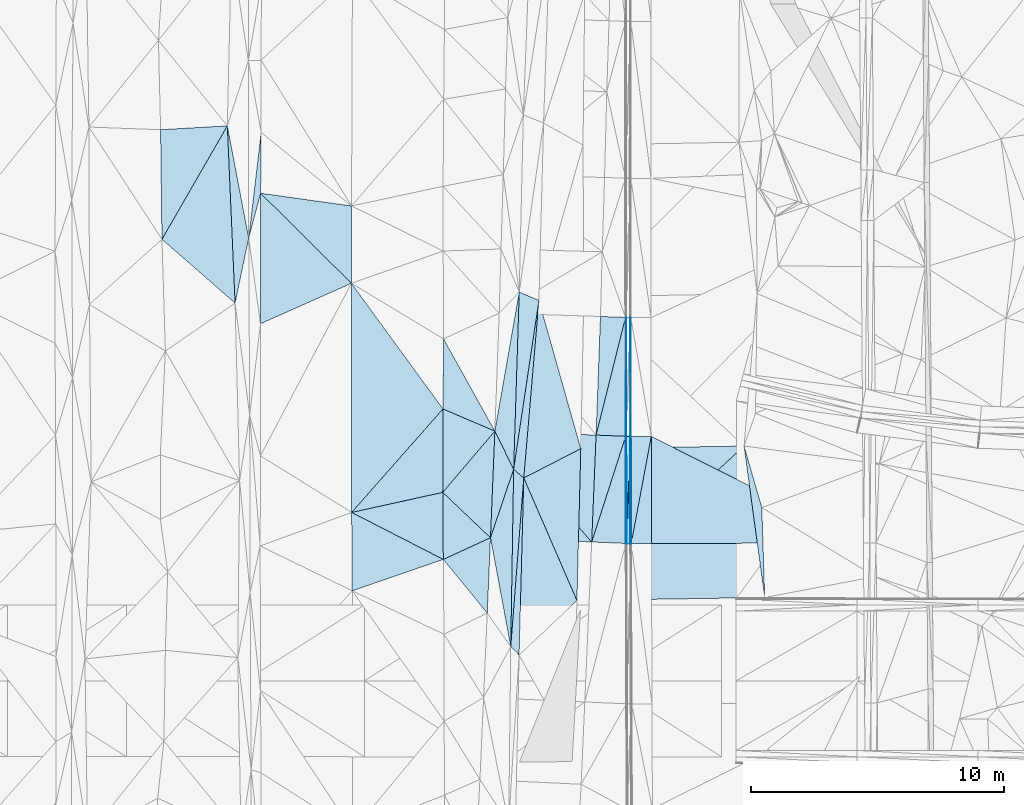
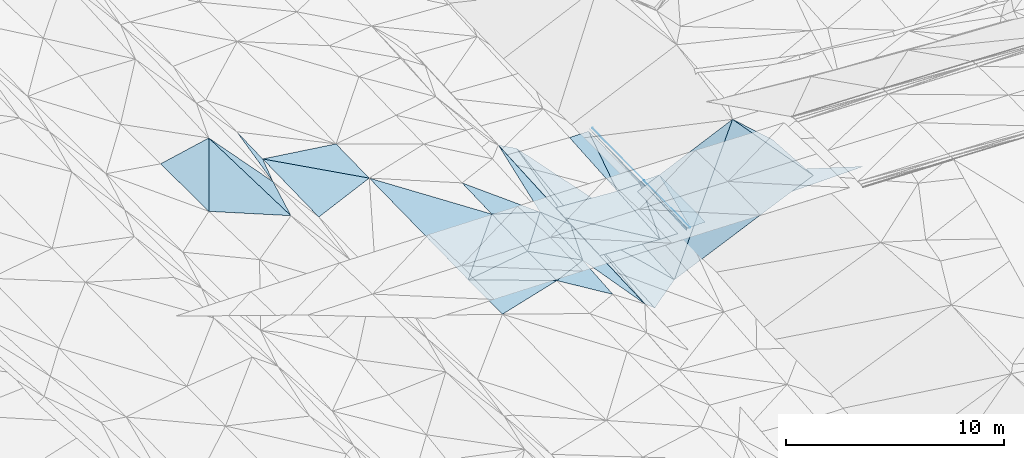
# One storey, part 109 of 275: 45 plates.
"""IFC2X3 building model written with IfcOpenShell, lengths in millimetres."""

from ifc_helpers import new_model, si_unit, frame, origin_with_axes, place, context, subcontext, project, spatial, polyline, outline, extrude, material, type_object, element, save


model = new_model("IFC2X3")

# Units and contexts
model_context = context("Model", 3, precision=1e-05, world=origin_with_axes())
body_context = subcontext(model_context, "Body", "Model", "MODEL_VIEW")
ifc_project = project(units=[si_unit("LENGTHUNIT", "METRE", prefix="MILLI"), si_unit("AREAUNIT", "SQUARE_METRE"), si_unit("VOLUMEUNIT", "CUBIC_METRE"), si_unit("MASSUNIT", "GRAM", prefix="KILO"), si_unit("TIMEUNIT", "SECOND"), si_unit("PLANEANGLEUNIT", "RADIAN"), si_unit("SOLIDANGLEUNIT", "STERADIAN"), si_unit("THERMODYNAMICTEMPERATUREUNIT", "DEGREE_CELSIUS"), si_unit("LUMINOUSINTENSITYUNIT", "LUMEN")], contexts=[model_context])

# Site, building, storey
site_placement = place(None, origin_with_axes())
site = spatial("IfcSite", under=ifc_project, at=site_placement, CompositionType="ELEMENT")
building_placement = place(site_placement, origin_with_axes())
building = spatial("IfcBuilding", under=site, at=building_placement, Name="Undefined", CompositionType="ELEMENT")
storey_placement = place(building_placement, origin_with_axes())
storey = spatial("IfcBuildingStorey", under=building, at=storey_placement, Name="Undefined", CompositionType="ELEMENT", Elevation=0.0)

# Plates
ifc_material = material()
plate_type_1 = type_object("IfcPlateType", PredefinedType="NOTDEFINED")
plate_1_placement = place(storey_placement, frame((-57611.7673058031, 72944.8939934645, 42524.9829680299), z_axis=(0.970243126930649, 0.00570694347081373, -0.24206549824388), x_axis=(0.00488659797822254, 0.999057078249222, 0.0431401849825259)))
element("IfcPlate", 1, at=plate_1_placement, inside=storey, type_object=plate_type_1, material=ifc_material, Name="00_PR", context=body_context, shape_type="SweptSolid", body=[
    extrude(outline(polyline([(0.0, 0.0), (4693.90673828125, 2.06455297302455e-08), (-1.32076799869537, 123.707763671875), (0.0, 0.0)])), frame((-8.85201319254618e-08, 2.18876761149539e-07, -0.5000001331573), z_axis=(0.0, 0.0, 1.0), x_axis=(1.0, 0.0, 0.0)), (0.0, 0.0, 1.0), 1.0),
])
plate_2_placement = place(storey_placement, frame((-57581.8262172482, 72938.2505207205, 42644.8357428941), z_axis=(0.97012620699227, 0.00640800800363628, -0.242516143669274), x_axis=(0.00219489801927136, -0.999842017004733, -0.0176386919750842)))
element("IfcPlate", 2, at=plate_2_placement, inside=storey, type_object=plate_type_1, material=ifc_material, Name="00_PR", context=body_context, shape_type="SweptSolid", body=[
    extrude(outline(polyline([(0.0, 0.0), (4228.6015625, 1.20053300634027e-09), (4227.474609375, 123.66544342041), (0.0, 0.0)])), frame((-8.85201319254618e-08, 2.18876761149539e-07, -0.5000001331573), z_axis=(0.0, 0.0, 1.0), x_axis=(1.0, 0.0, 0.0)), (0.0, 0.0, 1.0), 1.0),
])
plate_3_placement = place(storey_placement, frame((-57581.8261602477, 72938.2505079262, 42644.8359874113), z_axis=(0.970247976119799, 0.00638498660183058, -0.242029123829195), x_axis=(-0.00489946698072382, -0.998929707824003, -0.0459938479577186)))
element("IfcPlate", 3, at=plate_3_placement, inside=storey, type_object=plate_type_1, material=ifc_material, Name="00_PR", context=body_context, shape_type="SweptSolid", body=[
    extrude(outline(polyline([(0.0, 0.0), (4229.283203125, 2.02271621674299e-09), (-0.977516353130341, 123.710945129395), (0.0, 0.0)])), frame((-8.85201319254618e-08, 2.18876761149539e-07, -0.5000001331573), z_axis=(0.0, 0.0, 1.0), x_axis=(1.0, 0.0, 0.0)), (0.0, 0.0, 1.0), 1.0),
])
plate_type_2 = type_object("IfcPlateType", PredefinedType="NOTDEFINED")
plate_4_placement = place(storey_placement, frame((-57432.2372912618, 72936.8472508514, 42644.4570798487), z_axis=(0.000165595177624557, 0.0176390978391642, -0.999844405297973), x_axis=(-0.0332880189951421, -0.999290208308882, -0.0176348339762352)))
element("IfcPlate", 4, at=plate_4_placement, inside=storey, type_object=plate_type_2, material=ifc_material, Name="00_PR", context=body_context, shape_type="SweptSolid", body=[
    extrude(outline(polyline([(0.0, 0.0), (4229.5263671875, -2.51820893026888e-08), (3.5877788066864, 150.037628173828), (0.0, 0.0)])), frame((-8.85201319254618e-08, 2.18876761149539e-07, -0.5000001331573), z_axis=(0.0, 0.0, 1.0), x_axis=(1.0, 0.0, 0.0)), (0.0, 0.0, 1.0), 1.0),
])
plate_5_placement = place(storey_placement, frame((-57573.0299304181, 68710.3227504303, 42569.8700800233), z_axis=(1.18305001092025e-05, 0.0176442186452248, -0.999844328587425), x_axis=(0.0332880189977258, 0.99929020830875, 0.0176348339788603)))
element("IfcPlate", 5, at=plate_5_placement, inside=storey, type_object=plate_type_2, material=ifc_material, Name="00_PR", context=body_context, shape_type="SweptSolid", body=[
    extrude(outline(polyline([(0.0, 0.0), (4229.5263671875, -2.51820893026888e-08), (4.89290142059326, 149.926330566406), (0.0, 0.0)])), frame((-8.85201319254618e-08, 2.18876761149539e-07, -0.5000001331573), z_axis=(0.0, 0.0, 1.0), x_axis=(1.0, 0.0, 0.0)), (0.0, 0.0, 1.0), 1.0),
])
plate_type_3 = type_object("IfcPlateType", PredefinedType="NOTDEFINED")
plate_6_placement = place(storey_placement, frame((-57408.9591458897, 77630.8815297205, 42727.7001781578), z_axis=(0.019974485112096, 0.0176285701784254, -0.999645063739111), x_axis=(0.00143400803116008, -0.99984401935991, -0.017603424984539)))
element("IfcPlate", 6, at=plate_6_placement, inside=storey, type_object=plate_type_3, material=ifc_material, Name="00_PR", context=body_context, shape_type="SweptSolid", body=[
    extrude(outline(polyline([(0.0, 0.0), (4694.71142578125, 1.03318598121405e-08), (-0.00140420964453369, 30.0062637329102), (0.0, 0.0)])), frame((-8.85201319254618e-08, 2.18876761149539e-07, -0.5000001331573), z_axis=(0.0, 0.0, 1.0), x_axis=(1.0, 0.0, 0.0)), (0.0, 0.0, 1.0), 1.0),
])
plate_7_placement = place(storey_placement, frame((-57402.2269020101, 72936.9025004294, 42645.0571785886), z_axis=(0.0199481005942734, 0.0176842374568109, -0.999644607362162), x_axis=(0.00217946401974535, -0.999841952929564, -0.0176442369793032)))
element("IfcPlate", 7, at=plate_7_placement, inside=storey, type_object=plate_type_3, material=ifc_material, Name="00_PR", context=body_context, shape_type="SweptSolid", body=[
    extrude(outline(polyline([(0.0, 0.0), (4227.2724609375, 1.45300873555243e-08), (4227.29345703125, 30.0062198638916), (0.0, 0.0)])), frame((-8.85201319254618e-08, 2.18876761149539e-07, -0.5000001331573), z_axis=(0.0, 0.0, 1.0), x_axis=(1.0, 0.0, 0.0)), (0.0, 0.0, 1.0), 1.0),
])
plate_8_placement = place(storey_placement, frame((-57423.0138424193, 68710.222193699, 42569.8701804053), z_axis=(0.0199606315319578, 0.0176842603540002, -0.999644356821253), x_axis=(-0.00217946402561474, 0.999841952929493, 0.0176442369826318)))
element("IfcPlate", 8, at=plate_8_placement, inside=storey, type_object=plate_type_3, material=ifc_material, Name="00_PR", context=body_context, shape_type="SweptSolid", body=[
    extrude(outline(polyline([(0.0, 0.0), (4227.29296875, 2.75249476544559e-08), (4227.29345703125, 30.0065479278564), (0.0, 0.0)])), frame((-8.85201319254618e-08, 2.18876761149539e-07, -0.5000001331573), z_axis=(0.0, 0.0, 1.0), x_axis=(1.0, 0.0, 0.0)), (0.0, 0.0, 1.0), 1.0),
])
plate_type_4 = type_object("IfcPlateType", PredefinedType="NOTDEFINED")
plate_9_placement = place(storey_placement, frame((-73342.23711854, 85203.2767302003, 43148.5042106368), z_axis=(0.124920448690012, 0.0349312792920488, -0.991551656357906), x_axis=(0.0436736085227034, -0.998604956458779, -0.0296775479877732)))
element("IfcPlate", 9, at=plate_9_placement, inside=storey, type_object=plate_type_4, material=ifc_material, Name="00", context=body_context, shape_type="SweptSolid", body=[
    extrude(outline(polyline([(0.0, 0.0), (7008.6650390625, 2.55167833529413e-08), (4374.56884765625, 2796.93212890625), (0.0, 0.0)])), frame((-8.85201319254618e-08, 2.18876761149539e-07, -0.5000001331573), z_axis=(0.0, 0.0, 1.0), x_axis=(1.0, 0.0, 0.0)), (0.0, 0.0, 1.0), 1.0),
])
plate_type_5 = type_object("IfcPlateType", PredefinedType="NOTDEFINED")
plate_10_placement = place(storey_placement, frame((-62777.9322185656, 73148.520776183, 42618.778353892), z_axis=(-0.0316605255326336, 0.0202614611736181, -0.999293292439266), x_axis=(0.99871694562658, -0.038893467002911, -0.0324308609631148)))
element("IfcPlate", 10, at=plate_10_placement, inside=storey, type_object=plate_type_5, material=ifc_material, Name="00_PR", context=body_context, shape_type="SweptSolid", body=[
    extrude(outline(polyline([(0.0, 0.0), (4002.11376953125, 1.0986695997417e-08), (3995.87133789063, 4225.69580078125), (0.0, 0.0)])), frame((-8.85201319254618e-08, 2.18876761149539e-07, -0.5000001331573), z_axis=(0.0, 0.0, 1.0), x_axis=(1.0, 0.0, 0.0)), (0.0, 0.0, 1.0), 1.0),
])
plate_type_6 = type_object("IfcPlateType", PredefinedType="NOTDEFINED")
plate_11_placement = place(storey_placement, frame((-58954.2003882864, 68771.4770252661, 42408.8833550101), z_axis=(-0.0318150315981299, 0.0201263825966933, -0.999291114985009), x_axis=(-0.998587986679992, 0.0419150260022276, 0.0326368419678157)))
element("IfcPlate", 11, at=plate_11_placement, inside=storey, type_object=plate_type_6, material=ifc_material, Name="00_PR", context=body_context, shape_type="SweptSolid", body=[
    extrude(outline(polyline([(0.0, 0.0), (4002.13354492188, -1.1859810911119e-08), (4008.64697265625, 4213.578125), (0.0, 0.0)])), frame((-8.85201319254618e-08, 2.18876761149539e-07, -0.5000001331573), z_axis=(0.0, 0.0, 1.0), x_axis=(1.0, 0.0, 0.0)), (0.0, 0.0, 1.0), 1.0),
])
plate_type_7 = type_object("IfcPlateType", PredefinedType="NOTDEFINED")
plate_12_placement = place(storey_placement, frame((-57618.9634509243, 77639.5114144846, 42607.4133171386), z_axis=(0.0308423982583364, 0.0177578302044527, -0.999366502308389), x_axis=(-0.242519786054332, -0.969831527098107, -0.0247176539888915)))
element("IfcPlate", 12, at=plate_12_placement, inside=storey, type_object=plate_type_7, material=ifc_material, Name="00_PR", context=body_context, shape_type="SweptSolid", body=[
    extrude(outline(polyline([(0.0, 0.0), (4791.19091796875, 1.69820850715041e-08), (205.330871582031, 969.00634765625), (0.0, 0.0)])), frame((-8.85201319254618e-08, 2.18876761149539e-07, -0.5000001331573), z_axis=(0.0, 0.0, 1.0), x_axis=(1.0, 0.0, 0.0)), (0.0, 0.0, 1.0), 1.0),
])
plate_type_8 = type_object("IfcPlateType", PredefinedType="NOTDEFINED")
plate_13_placement = place(storey_placement, frame((-57612.2368329014, 72944.8999794223, 42524.6043218888), z_axis=(0.0311831407768184, 0.0176835519756192, -0.999357245293603), x_axis=(-0.306000644121153, -0.951665533274514, -0.0263878489986278)))
element("IfcPlate", 13, at=plate_13_placement, inside=storey, type_object=plate_type_8, material=ifc_material, Name="00_PR", context=body_context, shape_type="SweptSolid", body=[
    extrude(outline(polyline([(0.0, 0.0), (4385.3896484375, -8.94942786544561e-09), (312.913116455078, 1127.59887695313), (0.0, 0.0)])), frame((-8.85201319254618e-08, 2.18876761149539e-07, -0.5000001331573), z_axis=(0.0, 0.0, 1.0), x_axis=(1.0, 0.0, 0.0)), (0.0, 0.0, 1.0), 1.0),
])
plate_type_9 = type_object("IfcPlateType", PredefinedType="NOTDEFINED")
plate_14_placement = place(storey_placement, frame((-58780.9218707831, 72992.8633976808, 42488.9863218082), z_axis=(0.0311826941589554, 0.0176725039183032, -0.999357454662868), x_axis=(0.242519786058194, 0.969831527097058, 0.0247176539921822)))
element("IfcPlate", 14, at=plate_14_placement, inside=storey, type_object=plate_type_9, material=ifc_material, Name="00_PR", context=body_context, shape_type="SweptSolid", body=[
    extrude(outline(polyline([(0.0, 0.0), (4791.19091796875, 1.69820850715041e-08), (237.793197631836, 1145.7958984375), (0.0, 0.0)])), frame((-8.85201319254618e-08, 2.18876761149539e-07, -0.5000001331573), z_axis=(0.0, 0.0, 1.0), x_axis=(1.0, 0.0, 0.0)), (0.0, 0.0, 1.0), 1.0),
])
plate_type_10 = type_object("IfcPlateType", PredefinedType="NOTDEFINED")
plate_15_placement = place(storey_placement, frame((-58954.1689156606, 68771.4758148851, 42408.8833212797), z_axis=(0.031123817207974, 0.0177026689055965, -0.999358756161181), x_axis=(0.306000644124692, 0.951665533273248, 0.0263878490032564)))
element("IfcPlate", 15, at=plate_15_placement, inside=storey, type_object=plate_type_10, material=ifc_material, Name="00_PR", context=body_context, shape_type="SweptSolid", body=[
    extrude(outline(polyline([(0.0, 0.0), (4385.3896484375, -8.94942786544561e-09), (359.362823486328, 1304.421875), (0.0, 0.0)])), frame((-8.85201319254618e-08, 2.18876761149539e-07, -0.5000001331573), z_axis=(0.0, 0.0, 1.0), x_axis=(1.0, 0.0, 0.0)), (0.0, 0.0, 1.0), 1.0),
])
plate_type_11 = type_object("IfcPlateType", PredefinedType="NOTDEFINED")
plate_16_placement = place(storey_placement, frame((-56602.2285021653, 72938.3634877455, 42661.057178696), z_axis=(0.0199481419884617, 0.0176866005518615, -0.999644564728948), x_axis=(0.00217953798895441, -0.999841911083125, -0.0176465989867582)))
element("IfcPlate", 16, at=plate_16_placement, inside=storey, type_object=plate_type_11, material=ifc_material, Name="00_PR", context=body_context, shape_type="SweptSolid", body=[
    extrude(outline(polyline([(0.0, 0.0), (4226.70654296875, -2.71029421128333e-08), (4227.27197265625, 800.159851074219), (0.0, 0.0)])), frame((-8.85201319254618e-08, 2.18876761149539e-07, -0.5000001331573), z_axis=(0.0, 0.0, 1.0), x_axis=(1.0, 0.0, 0.0)), (0.0, 0.0, 1.0), 1.0),
])
plate_17_placement = place(storey_placement, frame((-57393.0137081003, 68710.298032481, 42570.4701786201), z_axis=(0.0199606315319578, 0.0176842603540002, -0.999644356821253), x_axis=(-0.00217946402561474, 0.999841952929493, 0.0176442369826318)))
element("IfcPlate", 17, at=plate_17_placement, inside=storey, type_object=plate_type_11, material=ifc_material, Name="00_PR", context=body_context, shape_type="SweptSolid", body=[
    extrude(outline(polyline([(0.0, 0.0), (4227.2724609375, 1.45300873555243e-08), (4227.27197265625, 800.159729003906), (0.0, 0.0)])), frame((-8.85201319254618e-08, 2.18876761149539e-07, -0.5000001331573), z_axis=(0.0, 0.0, 1.0), x_axis=(1.0, 0.0, 0.0)), (0.0, 0.0, 1.0), 1.0),
])
plate_type_12 = type_object("IfcPlateType", PredefinedType="NOTDEFINED")
plate_18_placement = place(storey_placement, frame((-56593.0162345531, 68712.3249772227, 42586.4701787613), z_axis=(0.0199481419884617, 0.0176866005518615, -0.999644564728948), x_axis=(-0.00217953798725381, 0.999841911083165, 0.017646598984668)))
element("IfcPlate", 18, at=plate_18_placement, inside=storey, type_object=plate_type_12, material=ifc_material, Name="00_PR", context=body_context, shape_type="SweptSolid", body=[
    extrude(outline(polyline([(0.0, 0.0), (4226.70654296875, -2.71029421128333e-08), (5.90985298156738, 8370.626953125), (0.0, 0.0)])), frame((-8.85201319254618e-08, 2.18876761149539e-07, -0.5000001331573), z_axis=(0.0, 0.0, 1.0), x_axis=(1.0, 0.0, 0.0)), (0.0, 0.0, 1.0), 1.0),
])
plate_type_13 = type_object("IfcPlateType", PredefinedType="NOTDEFINED")
plate_19_placement = place(storey_placement, frame((-64813.5027385307, 68082.8834617629, 42569.5005354058), z_axis=(-0.0426804082971666, 0.0190437265929373, -0.99890726257498), x_axis=(-0.944831486419599, -0.325770792464185, 0.0341592307786365)))
element("IfcPlate", 19, at=plate_19_placement, inside=storey, type_object=plate_type_13, material=ifc_material, Name="00", context=body_context, shape_type="SweptSolid", body=[
    extrude(outline(polyline([(0.0, 0.0), (3805.70629882813, -8.60018189996481e-09), (2821.63134765625, 2934.90991210938), (0.0, 0.0)])), frame((-8.85201319254618e-08, 2.18876761149539e-07, -0.5000001331573), z_axis=(0.0, 0.0, 1.0), x_axis=(1.0, 0.0, 0.0)), (0.0, 0.0, 1.0), 1.0),
])
plate_type_14 = type_object("IfcPlateType", PredefinedType="NOTDEFINED")
plate_20_placement = place(storey_placement, frame((-62777.9260650832, 73148.5205671894, 42619.5001794375), z_axis=(-0.0191133930236661, 0.0197827880947937, -0.999621588153397), x_axis=(0.441427943344498, -0.896914391230012, -0.0261905639333078)))
element("IfcPlate", 20, at=plate_20_placement, inside=storey, type_object=plate_type_14, material=ifc_material, Name="00", context=body_context, shape_type="SweptSolid", body=[
    extrude(outline(polyline([(0.0, 0.0), (1679.99438476563, -4.18367562815547e-10), (3701.21484375, 2013.80456542969), (0.0, 0.0)])), frame((-8.85201319254618e-08, 2.18876761149539e-07, -0.5000001331573), z_axis=(0.0, 0.0, 1.0), x_axis=(1.0, 0.0, 0.0)), (0.0, 0.0, 1.0), 1.0),
])
plate_type_15 = type_object("IfcPlateType", PredefinedType="NOTDEFINED")
plate_21_placement = place(storey_placement, frame((-64813.4943339714, 68082.8845709511, 42569.5002693584), z_axis=(-0.0258697642704339, 0.0212618108382933, -0.999439188093237), x_axis=(0.908495395471619, 0.417638659455222, -0.0146310127917117)))
element("IfcPlate", 21, at=plate_21_placement, inside=storey, type_object=plate_type_15, material=ifc_material, Name="00", context=body_context, shape_type="SweptSolid", body=[
    extrude(outline(polyline([(0.0, 0.0), (2050.43896484375, -2.61934474110603e-10), (692.534606933594, 2651.6025390625), (0.0, 0.0)])), frame((-8.85201319254618e-08, 2.18876761149539e-07, -0.5000001331573), z_axis=(0.0, 0.0, 1.0), x_axis=(1.0, 0.0, 0.0)), (0.0, 0.0, 1.0), 1.0),
])
plate_type_16 = type_object("IfcPlateType", PredefinedType="NOTDEFINED")
plate_22_placement = place(storey_placement, frame((-61037.9567948954, 78308.758523172, 42438.51508837), z_axis=(-0.243068020186197, 0.0195024123940885, -0.969813174520523), x_axis=(0.270729164444127, -0.958704112512645, -0.0871329109506124)))
element("IfcPlate", 22, at=plate_22_placement, inside=storey, type_object=plate_type_16, material=ifc_material, Name="00", context=body_context, shape_type="SweptSolid", body=[
    extrude(outline(polyline([(0.0, 0.0), (6105.61474609375, -1.0986695997417e-09), (6558.31787109375, 2548.60229492188), (0.0, 0.0)])), frame((-8.85201319254618e-08, 2.18876761149539e-07, -0.5000001331573), z_axis=(0.0, 0.0, 1.0), x_axis=(1.0, 0.0, 0.0)), (0.0, 0.0, 1.0), 1.0),
])
plate_type_17 = type_object("IfcPlateType", PredefinedType="NOTDEFINED")
plate_23_placement = place(storey_placement, frame((-62777.9290241403, 73148.5213279714, 42619.5002596744), z_axis=(-0.0250331635275349, 0.0212987743425121, -0.999459705508587), x_axis=(-0.648011945654678, -0.761630171598289, -1.54034312052298e-10)))
element("IfcPlate", 23, at=plate_23_placement, inside=storey, type_object=plate_type_17, material=ifc_material, Name="00", context=body_context, shape_type="SweptSolid", body=[
    extrude(outline(polyline([(0.0, 0.0), (3175.53149414063, -1.2136297300458e-08), (660.613830566406, 2129.7392578125), (0.0, 0.0)])), frame((-8.85201319254618e-08, 2.18876761149539e-07, -0.5000001331573), z_axis=(0.0, 0.0, 1.0), x_axis=(1.0, 0.0, 0.0)), (0.0, 0.0, 1.0), 1.0),
])
plate_type_18 = type_object("IfcPlateType", PredefinedType="NOTDEFINED")
plate_24_placement = place(storey_placement, frame((-61636.4209910781, 71298.1485185959, 42447.5354764292), z_axis=(-0.368607591225508, 0.0319238480473087, -0.929036765481744), x_axis=(-0.0264085334537319, -0.999366382056375, -0.0238626020453371)))
element("IfcPlate", 24, at=plate_24_placement, inside=storey, type_object=plate_type_18, material=ifc_material, Name="00", context=body_context, shape_type="SweptSolid", body=[
    extrude(outline(polyline([(0.0, 0.0), (6998.3984375, -1.49884726852179e-09), (6668.19580078125, 363.256500244141), (0.0, 0.0)])), frame((-8.85201319254618e-08, 2.18876761149539e-07, -0.5000001331573), z_axis=(0.0, 0.0, 1.0), x_axis=(1.0, 0.0, 0.0)), (0.0, 0.0, 1.0), 1.0),
])
plate_type_19 = type_object("IfcPlateType", PredefinedType="NOTDEFINED")
plate_25_placement = place(storey_placement, frame((-59384.9914534723, 72455.2860157477, 41906.5159062394), z_axis=(-0.24840415051612, 0.03065217146256, -0.96817138069197), x_axis=(-0.0252302263894751, -0.999364841727171, -0.0251664219936495)))
element("IfcPlate", 25, at=plate_25_placement, inside=storey, type_object=plate_type_19, material=ifc_material, Name="00", context=body_context, shape_type="SweptSolid", body=[
    extrude(outline(polyline([(0.0, 0.0), (6000.05810546875, -1.44646037369967e-08), (1199.59069824219, 2293.75146484375), (0.0, 0.0)])), frame((-8.85201319254618e-08, 2.18876761149539e-07, -0.5000001331573), z_axis=(0.0, 0.0, 1.0), x_axis=(1.0, 0.0, 0.0)), (0.0, 0.0, 1.0), 1.0),
])
plate_type_20 = type_object("IfcPlateType", PredefinedType="NOTDEFINED")
plate_26_placement = place(storey_placement, frame((-62150.0178155464, 64639.8915800065, 42422.5208428726), z_axis=(-0.284643470275703, 0.0255564382688083, -0.958292733611404), x_axis=(0.0162119844878004, 0.999629950839691, 0.0218433729813831)))
element("IfcPlate", 26, at=plate_26_placement, inside=storey, type_object=plate_type_20, material=ifc_material, Name="00", context=body_context, shape_type="SweptSolid", body=[
    extrude(outline(polyline([(0.0, 0.0), (7004.41259765625, -6.43194653093815e-09), (6664.6630859375, 423.15380859375), (0.0, 0.0)])), frame((-8.85201319254618e-08, 2.18876761149539e-07, -0.5000001331573), z_axis=(0.0, 0.0, 1.0), x_axis=(1.0, 0.0, 0.0)), (0.0, 0.0, 1.0), 1.0),
])
plate_type_21 = type_object("IfcPlateType", PredefinedType="NOTDEFINED")
plate_27_placement = place(storey_placement, frame((-72005.5914062298, 84944.6760190158, 43179.500101801), z_axis=(0.00480420180867921, 0.0207602129666131, -0.999772940823346), x_axis=(-0.00829846230797361, -0.999749224698919, -0.0207995970449649)))
element("IfcPlate", 27, at=plate_27_placement, inside=storey, type_object=plate_type_21, material=ifc_material, Name="00", context=body_context, shape_type="SweptSolid", body=[
    extrude(outline(polyline([(0.0, 0.0), (2403.892578125, -9.92440618574619e-09), (4177.10400390625, 457.362213134766), (0.0, 0.0)])), frame((-8.85201319254618e-08, 2.18876761149539e-07, -0.5000001331573), z_axis=(0.0, 0.0, 1.0), x_axis=(1.0, 0.0, 0.0)), (0.0, 0.0, 1.0), 1.0),
])
plate_type_22 = type_object("IfcPlateType", PredefinedType="NOTDEFINED")
plate_28_placement = place(storey_placement, frame((-52122.6267428324, 66578.886730483, 44922.5008904193), z_axis=(0.0533851486832181, -0.0272714839398636, -0.998201528782534), x_axis=(-0.134942564616383, 0.990260557962733, -0.034271439976881)))
element("IfcPlate", 28, at=plate_28_placement, inside=storey, type_object=plate_type_22, material=ifc_material, Name="00", context=body_context, shape_type="SweptSolid", body=[
    extrude(outline(polyline([(0.0, 0.0), (6040.0146484375, -2.14567990042269e-08), (3532.42260742188, 367.208679199219), (0.0, 0.0)])), frame((-8.85201319254618e-08, 2.18876761149539e-07, -0.5000001331573), z_axis=(0.0, 0.0, 1.0), x_axis=(1.0, 0.0, 0.0)), (0.0, 0.0, 1.0), 1.0),
])
plate_type_23 = type_object("IfcPlateType", PredefinedType="NOTDEFINED")
plate_29_placement = place(storey_placement, frame((-62036.4740069517, 71641.7128567152, 42575.524463247), z_axis=(-0.307875452734676, 0.0265656248725582, -0.951055715075909), x_axis=(0.0315371574401392, 0.999345750987464, 0.0177053010112308)))
element("IfcPlate", 29, at=plate_29_placement, inside=storey, type_object=plate_type_23, material=ifc_material, Name="00", context=body_context, shape_type="SweptSolid", body=[
    extrude(outline(polyline([(0.0, 0.0), (7003.55224609375, 5.03496266901493e-09), (6691.7509765625, 828.102661132813), (0.0, 0.0)])), frame((-8.85201319254618e-08, 2.18876761149539e-07, -0.5000001331573), z_axis=(0.0, 0.0, 1.0), x_axis=(1.0, 0.0, 0.0)), (0.0, 0.0, 1.0), 1.0),
])
plate_type_24 = type_object("IfcPlateType", PredefinedType="NOTDEFINED")
plate_30_placement = place(storey_placement, frame((-62036.3332915614, 71641.7107038526, 42575.5002915396), z_axis=(-0.026466311428408, 0.0222676149035619, -0.999401664840459), x_axis=(-0.0162119844524165, -0.99962995083942, -0.0218433730200494)))
element("IfcPlate", 30, at=plate_30_placement, inside=storey, type_object=plate_type_24, material=ifc_material, Name="00", context=body_context, shape_type="SweptSolid", body=[
    extrude(outline(polyline([(0.0, 0.0), (7004.41259765625, -6.43194653093815e-09), (2717.0927734375, 870.716979980469), (0.0, 0.0)])), frame((-8.85201319254618e-08, 2.18876761149539e-07, -0.5000001331573), z_axis=(0.0, 0.0, 1.0), x_axis=(1.0, 0.0, 0.0)), (0.0, 0.0, 1.0), 1.0),
])
plate_type_25 = type_object("IfcPlateType", PredefinedType="NOTDEFINED")
plate_31_placement = place(storey_placement, frame((-61037.9785055814, 78308.7603845117, 42438.5210941319), z_axis=(-0.286489295364452, 0.0232241191676793, -0.957801923119006), x_axis=(-0.0850471434767652, -0.996376107326645, 0.00127911494586048)))
element("IfcPlate", 31, at=plate_31_placement, inside=storey, type_object=plate_type_25, material=ifc_material, Name="00", context=body_context, shape_type="SweptSolid", body=[
    extrude(outline(polyline([(0.0, 0.0), (7036.1142578125, 4.46307240054011e-08), (6727.98193359375, 446.702911376953), (0.0, 0.0)])), frame((-8.85201319254618e-08, 2.18876761149539e-07, -0.5000001331573), z_axis=(0.0, 0.0, 1.0), x_axis=(1.0, 0.0, 0.0)), (0.0, 0.0, 1.0), 1.0),
])
plate_type_26 = type_object("IfcPlateType", PredefinedType="NOTDEFINED")
plate_32_placement = place(storey_placement, frame((-61815.4588896303, 78640.6789458435, 42699.5001954622), z_axis=(-0.0219184491762923, 0.0184013336292305, -0.999590402368076), x_axis=(-0.0315371573528826, -0.999345750989642, -0.0177053010436905)))
element("IfcPlate", 32, at=plate_32_placement, inside=storey, type_object=plate_type_26, material=ifc_material, Name="00", context=body_context, shape_type="SweptSolid", body=[
    extrude(outline(polyline([(0.0, 0.0), (7003.55224609375, 5.03496266901493e-09), (5520.3359375, 788.954956054688), (0.0, 0.0)])), frame((-8.85201319254618e-08, 2.18876761149539e-07, -0.5000001331573), z_axis=(0.0, 0.0, 1.0), x_axis=(1.0, 0.0, 0.0)), (0.0, 0.0, 1.0), 1.0),
])
plate_type_27 = type_object("IfcPlateType", PredefinedType="NOTDEFINED")
plate_33_placement = place(storey_placement, frame((-62777.9288966468, 73148.521621662, 42619.500266806), z_axis=(-0.0247782860007692, 0.0218943638956433, -0.999453187184107), x_axis=(-0.919025646149141, 0.392945775481193, 0.0313923438378977)))
element("IfcPlate", 33, at=plate_33_placement, inside=storey, type_object=plate_type_27, material=ifc_material, Name="00", context=body_context, shape_type="SweptSolid", body=[
    extrude(outline(polyline([(0.0, 0.0), (2229.84301757813, 1.56433088704944e-09), (3296.734375, 2552.51708984375), (0.0, 0.0)])), frame((-8.85201319254618e-08, 2.18876761149539e-07, -0.5000001331573), z_axis=(0.0, 0.0, 1.0), x_axis=(1.0, 0.0, 0.0)), (0.0, 0.0, 1.0), 1.0),
])
plate_type_28 = type_object("IfcPlateType", PredefinedType="NOTDEFINED")
plate_34_placement = place(storey_placement, frame((-68432.6236716831, 69937.9239719373, 42759.5006018613), z_axis=(-0.0443606593375041, 0.0220279466804254, -0.998772697598501), x_axis=(-0.00106605064077561, 0.999755263866601, 0.0220969660146958)))
element("IfcPlate", 34, at=plate_34_placement, inside=storey, type_object=plate_type_28, material=ifc_material, Name="00", context=body_context, shape_type="SweptSolid", body=[
    extrude(outline(polyline([(0.0, 0.0), (9051.0166015625, -5.84259396418929e-08), (4080.41455078125, 3613.31103515625), (0.0, 0.0)])), frame((-8.85201319254618e-08, 2.18876761149539e-07, -0.5000001331573), z_axis=(0.0, 0.0, 1.0), x_axis=(1.0, 0.0, 0.0)), (0.0, 0.0, 1.0), 1.0),
])
plate_type_29 = type_object("IfcPlateType", PredefinedType="NOTDEFINED")
plate_35_placement = place(storey_placement, frame((-64835.7105500805, 70729.9400931138, 42619.5002263133), z_axis=(-0.0234588358835298, 0.0199593012524043, -0.999525542101104), x_axis=(0.648011945659857, 0.761630171593882, 1.54034312049393e-10)))
element("IfcPlate", 35, at=plate_35_placement, inside=storey, type_object=plate_type_29, material=ifc_material, Name="00", context=body_context, shape_type="SweptSolid", body=[
    extrude(outline(polyline([(0.0, 0.0), (3175.53149414063, -1.2136297300458e-08), (-142.33837890625, 2597.33325195313), (0.0, 0.0)])), frame((-8.85201319254618e-08, 2.18876761149539e-07, -0.5000001331573), z_axis=(0.0, 0.0, 1.0), x_axis=(1.0, 0.0, 0.0)), (0.0, 0.0, 1.0), 1.0),
])
plate_type_30 = type_object("IfcPlateType", PredefinedType="NOTDEFINED")
plate_36_placement = place(storey_placement, frame((-68442.2624821628, 78986.7260160634, 42959.5002748619), z_axis=(-0.0242936541002638, 0.0233080906545805, -0.999433114960924), x_axis=(-0.913501409053542, -0.406636615623571, 0.0127215758222315)))
element("IfcPlate", 36, at=plate_36_placement, inside=storey, type_object=plate_type_30, material=ifc_material, Name="00", context=body_context, shape_type="SweptSolid", body=[
    extrude(outline(polyline([(0.0, 0.0), (3930.33081054688, -1.04046193882823e-08), (1830.04956054688, 4706.9541015625), (0.0, 0.0)])), frame((-8.85201319254618e-08, 2.18876761149539e-07, -0.5000001331573), z_axis=(0.0, 0.0, 1.0), x_axis=(1.0, 0.0, 0.0)), (0.0, 0.0, 1.0), 1.0),
])
plate_type_31 = type_object("IfcPlateType", PredefinedType="NOTDEFINED")
plate_37_placement = place(storey_placement, frame((-64827.2212388256, 74024.728748666, 42689.5005778582), z_axis=(-0.0435739584732718, 0.0213330634759226, -0.998822411916003), x_axis=(-0.00257905034408619, -0.999771061974429, -0.0212408130222067)))
element("IfcPlate", 37, at=plate_37_placement, inside=storey, type_object=plate_type_31, material=ifc_material, Name="00", context=body_context, shape_type="SweptSolid", body=[
    extrude(outline(polyline([(0.0, 0.0), (3295.54248046875, -6.83940015733242e-10), (4093.68115234375, 3598.27392578125), (0.0, 0.0)])), frame((-8.85201319254618e-08, 2.18876761149539e-07, -0.5000001331573), z_axis=(0.0, 0.0, 1.0), x_axis=(1.0, 0.0, 0.0)), (0.0, 0.0, 1.0), 1.0),
])
plate_type_32 = type_object("IfcPlateType", PredefinedType="NOTDEFINED")
plate_38_placement = place(storey_placement, frame((-64813.5028776695, 68082.8831915766, 42569.5005368116), z_axis=(-0.0429550673637558, 0.0185077020346054, -0.998905564682254), x_axis=(-0.888939686651013, 0.455640531608657, 0.0466683988602477)))
element("IfcPlate", 38, at=plate_38_placement, inside=storey, type_object=plate_type_32, material=ifc_material, Name="00", context=body_context, shape_type="SweptSolid", body=[
    extrude(outline(polyline([(0.0, 0.0), (4071.27734375, -6.3664629124105e-10), (1228.189453125, 2345.51708984375), (0.0, 0.0)])), frame((-8.85201319254618e-08, 2.18876761149539e-07, -0.5000001331573), z_axis=(0.0, 0.0, 1.0), x_axis=(1.0, 0.0, 0.0)), (0.0, 0.0, 1.0), 1.0),
])
plate_type_33 = type_object("IfcPlateType", PredefinedType="NOTDEFINED")
plate_39_placement = place(storey_placement, frame((-68436.2700395697, 82039.8642475964, 43019.5002805921), z_axis=(-0.0278769488353411, 0.0196951797125498, -0.999417318050734), x_axis=(-0.00196292231494266, -0.999805031172402, -0.0196480680561047)))
element("IfcPlate", 39, at=plate_39_placement, inside=storey, type_object=plate_type_33, material=ifc_material, Name="00", context=body_context, shape_type="SweptSolid", body=[
    extrude(outline(polyline([(0.0, 0.0), (3053.7353515625, -1.68511178344488e-08), (-496.539428710938, 3591.66381835938), (0.0, 0.0)])), frame((-8.85201319254618e-08, 2.18876761149539e-07, -0.5000001331573), z_axis=(0.0, 0.0, 1.0), x_axis=(1.0, 0.0, 0.0)), (0.0, 0.0, 1.0), 1.0),
])
plate_type_34 = type_object("IfcPlateType", PredefinedType="NOTDEFINED")
plate_40_placement = place(storey_placement, frame((-62950.6793782986, 68939.2258596724, 42539.500230508), z_axis=(-0.0246808609297005, 0.0186727069412678, -0.999520977828507), x_axis=(-0.908495395487411, -0.417638659420716, 0.0146310127961118)))
element("IfcPlate", 40, at=plate_40_placement, inside=storey, type_object=plate_type_34, material=ifc_material, Name="00", context=body_context, shape_type="SweptSolid", body=[
    extrude(outline(polyline([(0.0, 0.0), (2050.43896484375, -2.61934474110603e-10), (965.841979980469, 2415.27416992188), (0.0, 0.0)])), frame((-8.85201319254618e-08, 2.18876761149539e-07, -0.5000001331573), z_axis=(0.0, 0.0, 1.0), x_axis=(1.0, 0.0, 0.0)), (0.0, 0.0, 1.0), 1.0),
])
plate_type_35 = type_object("IfcPlateType", PredefinedType="NOTDEFINED")
plate_41_placement = place(storey_placement, frame((-73036.1496658231, 78204.3885863875, 42940.5034577013), z_axis=(0.112407373996788, 0.0344290167628625, -0.99306556937389), x_axis=(-0.0436736085734124, 0.99860495645529, 0.0296775480305467)))
element("IfcPlate", 41, at=plate_41_placement, inside=storey, type_object=plate_type_35, material=ifc_material, Name="00", context=body_context, shape_type="SweptSolid", body=[
    extrude(outline(polyline([(0.0, 0.0), (7008.6650390625, 2.55167833529413e-08), (2545.42407226563, 654.552124023438), (0.0, 0.0)])), frame((-8.85201319254618e-08, 2.18876761149539e-07, -0.5000001331573), z_axis=(0.0, 0.0, 1.0), x_axis=(1.0, 0.0, 0.0)), (0.0, 0.0, 1.0), 1.0),
])
plate_type_36 = type_object("IfcPlateType", PredefinedType="NOTDEFINED")
plate_42_placement = place(storey_placement, frame((-61636.3618809056, 71298.1474181375, 42447.5161499606), z_axis=(-0.250387004767609, 0.0297227750431726, -0.96768946697132), x_axis=(0.394710722327103, -0.909552590323909, -0.13006740988843)))
element("IfcPlate", 42, at=plate_42_placement, inside=storey, type_object=plate_type_36, material=ifc_material, Name="00", context=body_context, shape_type="SweptSolid", body=[
    extrude(outline(polyline([(0.0, 0.0), (5320.318359375, 2.79833329841495e-08), (6310.14990234375, 3026.48095703125), (0.0, 0.0)])), frame((-8.85201319254618e-08, 2.18876761149539e-07, -0.5000001331573), z_axis=(0.0, 0.0, 1.0), x_axis=(1.0, 0.0, 0.0)), (0.0, 0.0, 1.0), 1.0),
])
plate_type_37 = type_object("IfcPlateType", PredefinedType="NOTDEFINED")
plate_43_placement = place(storey_placement, frame((-75923.4993537983, 80724.0490562358, 42665.5065288611), z_axis=(0.16058475970183, 0.0138797190047839, -0.986924459293544), x_axis=(-0.0125815925230402, 0.999848668611656, 0.0120143000246908)))
element("IfcPlate", 43, at=plate_43_placement, inside=storey, type_object=plate_type_37, material=ifc_material, Name="00", context=body_context, shape_type="SweptSolid", body=[
    extrude(outline(polyline([(0.0, 0.0), (4328.17578125, -1.90630089491606e-08), (4451.86572265625, 2672.18530273438), (0.0, 0.0)])), frame((-8.85201319254618e-08, 2.18876761149539e-07, -0.5000001331573), z_axis=(0.0, 0.0, 1.0), x_axis=(1.0, 0.0, 0.0)), (0.0, 0.0, 1.0), 1.0),
])
plate_type_38 = type_object("IfcPlateType", PredefinedType="NOTDEFINED")
plate_44_placement = place(storey_placement, frame((-59536.0504716256, 66459.0299319994, 41755.54161001), z_axis=(0.39921854558515, 0.0130075452231543, -0.916763522740813), x_axis=(0.0252302264398482, 0.99936484172602, 0.025166421988852)))
element("IfcPlate", 44, at=plate_44_placement, inside=storey, type_object=plate_type_38, material=ifc_material, Name="00", context=body_context, shape_type="SweptSolid", body=[
    extrude(outline(polyline([(0.0, 0.0), (6000.05810546875, -1.44646037369967e-08), (6338.16552734375, 7025.16943359375), (0.0, 0.0)])), frame((-8.85201319254618e-08, 2.18876761149539e-07, -0.5000001331573), z_axis=(0.0, 0.0, 1.0), x_axis=(1.0, 0.0, 0.0)), (0.0, 0.0, 1.0), 1.0),
])
plate_type_39 = type_object("IfcPlateType", PredefinedType="NOTDEFINED")
plate_45_placement = place(storey_placement, frame((-52937.5123336164, 72560.0995574777, 44715.5402352907), z_axis=(0.392455983653809, 0.0216568119996374, -0.919515787460082), x_axis=(0.134942564543581, -0.990260557970684, 0.0342714400338228)))
element("IfcPlate", 45, at=plate_45_placement, inside=storey, type_object=plate_type_39, material=ifc_material, Name="00", context=body_context, shape_type="SweptSolid", body=[
    extrude(outline(polyline([(0.0, 0.0), (6040.0146484375, -2.14567990042269e-08), (5049.77685546875, 8001.56884765625), (0.0, 0.0)])), frame((-8.85201319254618e-08, 2.18876761149539e-07, -0.5000001331573), z_axis=(0.0, 0.0, 1.0), x_axis=(1.0, 0.0, 0.0)), (0.0, 0.0, 1.0), 1.0),
])

save(model, "model.ifc")
